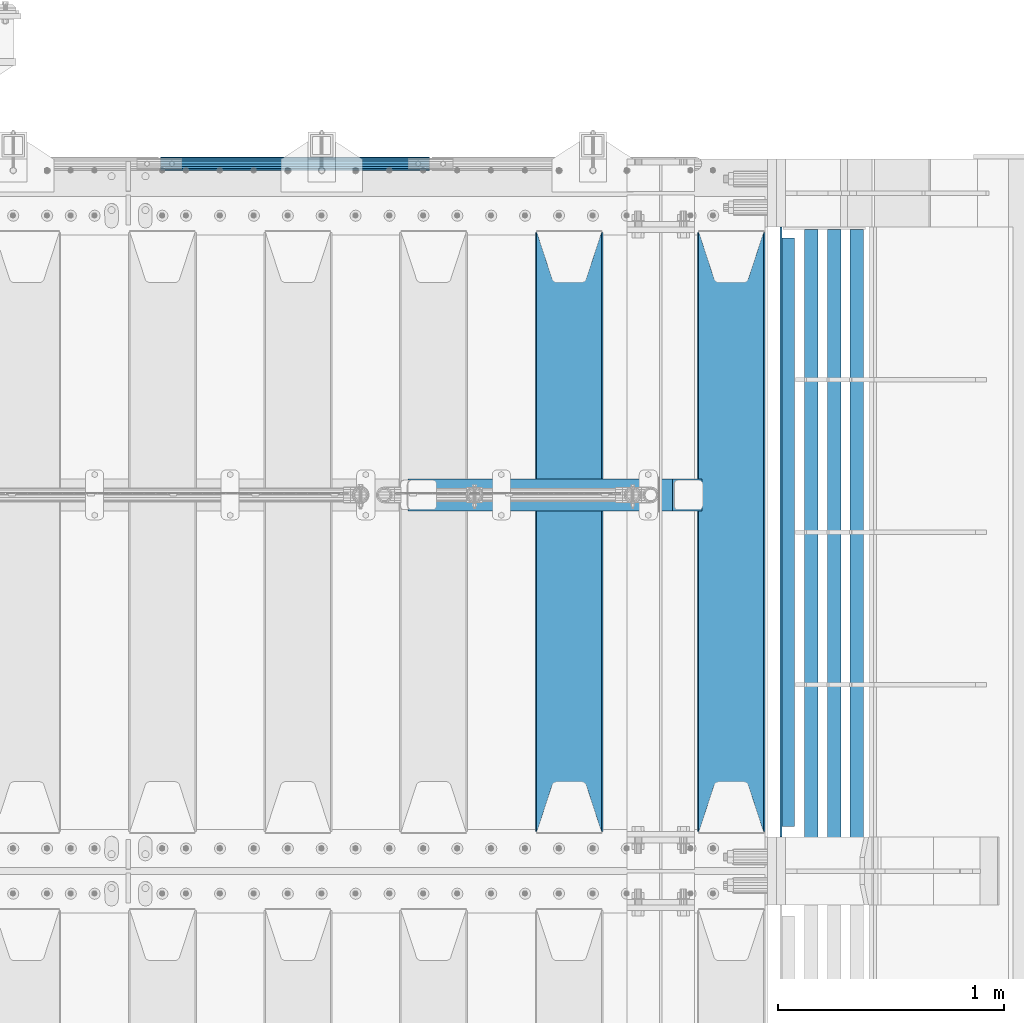
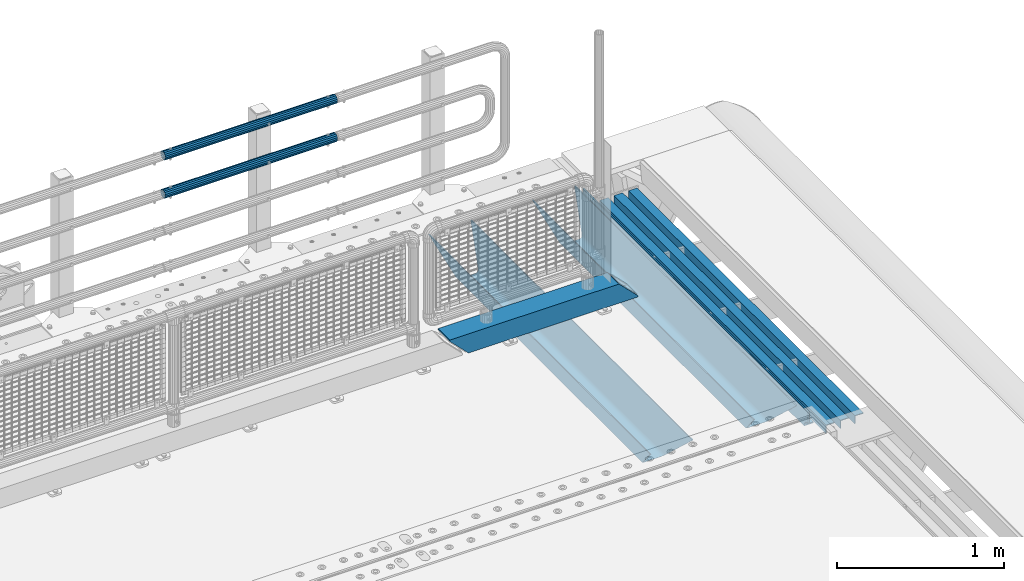
# One storey, part 118 of 219: 9 beams.
"""IFC2X3 building model written with IfcOpenShell, lengths in millimetres."""

from ifc_helpers import new_model, si_unit, frame, origin_with_axes, place, context, subcontext, project, spatial, faceted_brep, material, type_object, element, save


model = new_model("IFC2X3")

# Units and contexts
model_context = context("Model", 3, precision=1e-05, world=origin_with_axes())
body_context = subcontext(model_context, "Body", "Model", "MODEL_VIEW")
ifc_project = project(units=[si_unit("LENGTHUNIT", "METRE", prefix="MILLI"), si_unit("AREAUNIT", "SQUARE_METRE"), si_unit("VOLUMEUNIT", "CUBIC_METRE"), si_unit("MASSUNIT", "GRAM", prefix="KILO"), si_unit("TIMEUNIT", "SECOND"), si_unit("PLANEANGLEUNIT", "RADIAN"), si_unit("SOLIDANGLEUNIT", "STERADIAN"), si_unit("THERMODYNAMICTEMPERATUREUNIT", "DEGREE_CELSIUS"), si_unit("LUMINOUSINTENSITYUNIT", "LUMEN")], contexts=[model_context])

# Site, building, storey
site_placement = place(None, origin_with_axes())
site = spatial("IfcSite", under=ifc_project, at=site_placement, CompositionType="ELEMENT")
building_placement = place(site_placement, origin_with_axes())
building = spatial("IfcBuilding", under=site, at=building_placement, Name="Standard", CompositionType="ELEMENT")
storey_placement = place(building_placement, origin_with_axes())
storey = spatial("IfcBuildingStorey", under=building, at=storey_placement, Name="Undefined", CompositionType="ELEMENT", Elevation=0.0)

# Beams
ifc_material_1 = material(Name="STEEL/S355N")
beam_type_1 = type_object("IfcBeamType", PredefinedType="NOTDEFINED")
beam_1_placement = place(storey_placement, frame((13867.0, 30175.0, -115.0), z_axis=(0.0, 0.0, 1.0), x_axis=(0.0, 1.0, 0.0)))
element("IfcBeam", 1, at=beam_1_placement, inside=storey, type_object=beam_type_1, material=ifc_material_1, context=body_context, shape_type="Brep", body=[
    faceted_brep([(0.0, 150.0, 115.0), (0.0, 143.690000000001, 115.0), (2650.00000000297, 143.690000000001, 115.0), (2650.00000000297, 150.0, 115.0), (2650.00000000297, 142.0595652184, 110.000000003094), (2650.00000000297, 148.3695652184, 110.000000003094), (2441.90079219209, -80.110360073113, -98.0992078077845), (2437.7588105432, -77.5672621345566, -102.241189456673), (2434.06523489747, -74.4080125315541, -105.934765102404), (2430.9108609509, -70.7102721255742, -109.089139048974), (2428.37322971128, -66.5649389910068, -111.626770288588), (2426.51472138055, -62.0739139532889, -113.485278619323), (2425.38102192092, -57.3475956567672, -114.618978078955), (2424.99999999988, -52.5021667386536, -115.0), (2424.99999999988, 52.5021667386536, -115.0), (2425.38102192092, 57.3475956567672, -114.618978078955), (2426.51472138055, 62.0739139532889, -113.485278619323), (2428.37322971128, 66.5649389910068, -111.626770288588), (2430.9108609509, 70.7102721255742, -109.089139048974), (2434.06523489747, 74.4080125315541, -105.934765102404), (2437.7588105432, 77.5672621345566, -102.241189456673), (2441.90079219209, 80.110360073113, -98.0992078077846), (2446.38936140512, 81.9747917625791, -93.6106385947584), (2448.2494850041, 76.2713538057269, -91.7505149957729), (2444.62967112263, 74.7677798626082, -95.3703288772456), (2441.28936334127, 72.7168944282894, -98.710636658607), (2438.31067330439, 70.1691124903828, -101.689326695487), (2435.76682334748, 67.1870637758839, -104.233176652398), (2433.72034654134, 63.8440531834913, -106.279653458539), (2432.22154950042, 60.2222587982342, -107.778450499454), (2431.30727574265, 56.4107117849107, -108.692724257221), (2430.99999999987, 52.5031078186894, -109.0), (2430.99999999987, -52.5031078186894, -109.0), (2431.30727574265, -56.4107117849107, -108.692724257221), (2432.22154950042, -60.2222587982342, -107.778450499454), (2433.72034654134, -63.8440531834913, -106.279653458539), (2435.76682334748, -67.1870637758839, -104.233176652398), (2438.31067330439, -70.1691124903828, -101.689326695487), (2441.28936334127, -72.7168944282894, -98.7106366586071), (2444.62967112263, -74.7677798626082, -95.3703288772457), (2448.2494850041, -76.2713538057269, -91.7505149957729), (2650.00000000297, -142.0595652184, 110.000000003094), (2650.00000000297, -148.3695652184, 110.000000003094), (2446.38936140512, -81.9747917625791, -93.6106385947584), (2650.00000000297, -143.690000000001, 115.0), (2650.00000000297, -150.0, 115.0), (0.0, -143.690000000001, 115.0), (0.0, -150.0, 115.0), (0.0, -148.369565218261, 110.000000002667), (203.610638597427, -81.9747917625791, -93.6106385947584), (208.09920781045, -80.110360073113, -98.0992078077845), (212.241189459342, -77.5672621345566, -102.241189456673), (215.93476510507, -74.4080125315541, -105.934765102404), (219.089139051641, -70.7102721255742, -109.089139048974), (221.626770291256, -66.5649389910068, -111.626770288588), (223.485278621989, -62.0739139532889, -113.485278619323), (224.618978081624, -57.3475956567672, -114.618978078955), (225.000000002663, -52.5021667386536, -115.0), (225.000000002663, 52.5021667386536, -115.0), (224.618978081624, 57.3475956567672, -114.618978078955), (223.485278621989, 62.0739139532889, -113.485278619323), (221.626770291256, 66.5649389910068, -111.626770288588), (219.089139051641, 70.7102721255742, -109.089139048974), (215.93476510507, 74.4080125315541, -105.934765102404), (212.241189459342, 77.5672621345566, -102.241189456673), (208.09920781045, 80.110360073113, -98.0992078077846), (203.610638597427, 81.9747917625791, -93.6106385947584), (0.0, 148.369565218261, 110.000000002667), (0.0, 142.059565218262, 110.000000002667), (201.750514998439, 76.2713538057269, -91.7505149957729), (205.370328879915, 74.7677798626082, -95.3703288772456), (208.710636661275, 72.7168944282894, -98.710636658607), (211.689326698157, 70.1691124903828, -101.689326695487), (214.233176655063, 67.1870637758839, -104.233176652398), (216.279653461206, 63.8440531834913, -106.279653458539), (217.778450502123, 60.2222587982342, -107.778450499454), (218.69272425989, 56.4107117849107, -108.692724257221), (219.00000000267, 52.5031078186894, -109.0), (219.00000000267, -52.5031078186894, -109.0), (218.69272425989, -56.4107117849107, -108.692724257221), (217.778450502123, -60.2222587982342, -107.778450499454), (216.279653461206, -63.8440531834913, -106.279653458539), (214.233176655063, -67.1870637758839, -104.233176652398), (211.689326698157, -70.1691124903828, -101.689326695487), (208.710636661275, -72.7168944282894, -98.7106366586071), (205.370328879915, -74.7677798626082, -95.3703288772457), (201.750514998439, -76.2713538057269, -91.7505149957729), (0.0, -142.059565218262, 110.000000002667)], [[[0, 1, 2, 3]], [[3, 2, 4, 5]], [[6, 7, 8, 9, 10, 11, 12, 13, 14, 15, 16, 17, 18, 19, 20, 21, 22, 5, 4, 23, 24, 25, 26, 27, 28, 29, 30, 31, 32, 33, 34, 35, 36, 37, 38, 39, 40, 41, 42, 43]], [[44, 45, 42, 41]], [[46, 47, 45, 44]], [[43, 42, 45, 47, 48, 49]], [[6, 43, 49, 50]], [[7, 6, 50, 51]], [[8, 7, 51, 52]], [[9, 8, 52, 53]], [[10, 9, 53, 54]], [[11, 10, 54, 55]], [[12, 11, 55, 56]], [[13, 12, 56, 57]], [[14, 13, 57, 58]], [[15, 14, 58, 59]], [[16, 15, 59, 60]], [[17, 16, 60, 61]], [[18, 17, 61, 62]], [[19, 18, 62, 63]], [[20, 19, 63, 64]], [[21, 20, 64, 65]], [[22, 21, 65, 66]], [[0, 3, 5, 22, 66, 67]], [[1, 0, 67, 68]], [[23, 4, 2, 1, 68, 69]], [[24, 23, 69, 70]], [[25, 24, 70, 71]], [[26, 25, 71, 72]], [[27, 26, 72, 73]], [[28, 27, 73, 74]], [[29, 28, 74, 75]], [[30, 29, 75, 76]], [[31, 30, 76, 77]], [[32, 31, 77, 78]], [[33, 32, 78, 79]], [[34, 33, 79, 80]], [[35, 34, 80, 81]], [[36, 35, 81, 82]], [[37, 36, 82, 83]], [[38, 37, 83, 84]], [[39, 38, 84, 85]], [[40, 39, 85, 86]], [[46, 44, 41, 40, 86, 87]], [[47, 46, 87, 48]], [[86, 85, 84, 83, 82, 81, 80, 79, 78, 77, 76, 75, 74, 73, 72, 71, 70, 69, 68, 67, 66, 65, 64, 63, 62, 61, 60, 59, 58, 57, 56, 55, 54, 53, 52, 51, 50, 49, 48, 87]]]),
])
beam_2_placement = place(storey_placement, frame((13150.0, 30175.0, -115.0), z_axis=(0.0, 0.0, 1.0), x_axis=(0.0, 1.0, 0.0)))
element("IfcBeam", 2, at=beam_2_placement, inside=storey, type_object=beam_type_1, material=ifc_material_1, context=body_context, shape_type="Brep", body=[
    faceted_brep([(0.0, 150.0, 115.0), (0.0, 143.690000000001, 115.0), (2650.00000000297, 143.690000000001, 115.0), (2650.00000000297, 150.0, 115.0), (2650.00000000297, 142.0595652184, 110.000000003094), (2650.00000000297, 148.3695652184, 110.000000003094), (2441.90079219209, -80.110360073113, -98.0992078077845), (2437.7588105432, -77.5672621345566, -102.241189456673), (2434.06523489747, -74.4080125315541, -105.934765102404), (2430.9108609509, -70.7102721255742, -109.089139048974), (2428.37322971128, -66.5649389910068, -111.626770288588), (2426.51472138055, -62.0739139532889, -113.485278619323), (2425.38102192092, -57.3475956567672, -114.618978078955), (2424.99999999988, -52.5021667386536, -115.0), (2424.99999999988, 52.5021667386536, -115.0), (2425.38102192092, 57.3475956567672, -114.618978078955), (2426.51472138055, 62.0739139532889, -113.485278619323), (2428.37322971128, 66.5649389910068, -111.626770288588), (2430.9108609509, 70.7102721255742, -109.089139048974), (2434.06523489747, 74.4080125315541, -105.934765102404), (2437.7588105432, 77.5672621345566, -102.241189456673), (2441.90079219209, 80.110360073113, -98.0992078077846), (2446.38936140512, 81.9747917625791, -93.6106385947584), (2448.2494850041, 76.2713538057269, -91.7505149957729), (2444.62967112263, 74.7677798626082, -95.3703288772456), (2441.28936334127, 72.7168944282894, -98.710636658607), (2438.31067330439, 70.1691124903828, -101.689326695487), (2435.76682334748, 67.1870637758839, -104.233176652398), (2433.72034654134, 63.8440531834913, -106.279653458539), (2432.22154950042, 60.2222587982342, -107.778450499454), (2431.30727574265, 56.4107117849107, -108.692724257221), (2430.99999999987, 52.5031078186894, -109.0), (2430.99999999987, -52.5031078186894, -109.0), (2431.30727574265, -56.4107117849107, -108.692724257221), (2432.22154950042, -60.2222587982342, -107.778450499454), (2433.72034654134, -63.8440531834913, -106.279653458539), (2435.76682334748, -67.1870637758839, -104.233176652398), (2438.31067330439, -70.1691124903828, -101.689326695487), (2441.28936334127, -72.7168944282894, -98.7106366586071), (2444.62967112263, -74.7677798626082, -95.3703288772457), (2448.2494850041, -76.2713538057269, -91.7505149957729), (2650.00000000297, -142.0595652184, 110.000000003094), (2650.00000000297, -148.3695652184, 110.000000003094), (2446.38936140512, -81.9747917625791, -93.6106385947584), (2650.00000000297, -143.690000000001, 115.0), (2650.00000000297, -150.0, 115.0), (0.0, -143.690000000001, 115.0), (0.0, -150.0, 115.0), (0.0, -148.369565218261, 110.000000002667), (203.610638597427, -81.9747917625791, -93.6106385947584), (208.09920781045, -80.110360073113, -98.0992078077845), (212.241189459342, -77.5672621345566, -102.241189456673), (215.93476510507, -74.4080125315541, -105.934765102404), (219.089139051641, -70.7102721255742, -109.089139048974), (221.626770291256, -66.5649389910068, -111.626770288588), (223.485278621989, -62.0739139532889, -113.485278619323), (224.618978081624, -57.3475956567672, -114.618978078955), (225.000000002663, -52.5021667386536, -115.0), (225.000000002663, 52.5021667386536, -115.0), (224.618978081624, 57.3475956567672, -114.618978078955), (223.485278621989, 62.0739139532889, -113.485278619323), (221.626770291256, 66.5649389910068, -111.626770288588), (219.089139051641, 70.7102721255742, -109.089139048974), (215.93476510507, 74.4080125315541, -105.934765102404), (212.241189459342, 77.5672621345566, -102.241189456673), (208.09920781045, 80.110360073113, -98.0992078077846), (203.610638597427, 81.9747917625791, -93.6106385947584), (0.0, 148.369565218261, 110.000000002667), (0.0, 142.059565218262, 110.000000002667), (201.750514998439, 76.2713538057269, -91.7505149957729), (205.370328879915, 74.7677798626082, -95.3703288772456), (208.710636661275, 72.7168944282894, -98.710636658607), (211.689326698157, 70.1691124903828, -101.689326695487), (214.233176655063, 67.1870637758839, -104.233176652398), (216.279653461206, 63.8440531834913, -106.279653458539), (217.778450502123, 60.2222587982342, -107.778450499454), (218.69272425989, 56.4107117849107, -108.692724257221), (219.00000000267, 52.5031078186894, -109.0), (219.00000000267, -52.5031078186894, -109.0), (218.69272425989, -56.4107117849107, -108.692724257221), (217.778450502123, -60.2222587982342, -107.778450499454), (216.279653461206, -63.8440531834913, -106.279653458539), (214.233176655063, -67.1870637758839, -104.233176652398), (211.689326698157, -70.1691124903828, -101.689326695487), (208.710636661275, -72.7168944282894, -98.7106366586071), (205.370328879915, -74.7677798626082, -95.3703288772457), (201.750514998439, -76.2713538057269, -91.7505149957729), (0.0, -142.059565218262, 110.000000002667)], [[[0, 1, 2, 3]], [[3, 2, 4, 5]], [[6, 7, 8, 9, 10, 11, 12, 13, 14, 15, 16, 17, 18, 19, 20, 21, 22, 5, 4, 23, 24, 25, 26, 27, 28, 29, 30, 31, 32, 33, 34, 35, 36, 37, 38, 39, 40, 41, 42, 43]], [[44, 45, 42, 41]], [[46, 47, 45, 44]], [[43, 42, 45, 47, 48, 49]], [[6, 43, 49, 50]], [[7, 6, 50, 51]], [[8, 7, 51, 52]], [[9, 8, 52, 53]], [[10, 9, 53, 54]], [[11, 10, 54, 55]], [[12, 11, 55, 56]], [[13, 12, 56, 57]], [[14, 13, 57, 58]], [[15, 14, 58, 59]], [[16, 15, 59, 60]], [[17, 16, 60, 61]], [[18, 17, 61, 62]], [[19, 18, 62, 63]], [[20, 19, 63, 64]], [[21, 20, 64, 65]], [[22, 21, 65, 66]], [[0, 3, 5, 22, 66, 67]], [[1, 0, 67, 68]], [[23, 4, 2, 1, 68, 69]], [[24, 23, 69, 70]], [[25, 24, 70, 71]], [[26, 25, 71, 72]], [[27, 26, 72, 73]], [[28, 27, 73, 74]], [[29, 28, 74, 75]], [[30, 29, 75, 76]], [[31, 30, 76, 77]], [[32, 31, 77, 78]], [[33, 32, 78, 79]], [[34, 33, 79, 80]], [[35, 34, 80, 81]], [[36, 35, 81, 82]], [[37, 36, 82, 83]], [[38, 37, 83, 84]], [[39, 38, 84, 85]], [[40, 39, 85, 86]], [[46, 44, 41, 40, 86, 87]], [[47, 46, 87, 48]], [[86, 85, 84, 83, 82, 81, 80, 79, 78, 77, 76, 75, 74, 73, 72, 71, 70, 69, 68, 67, 66, 65, 64, 63, 62, 61, 60, 59, 58, 57, 56, 55, 54, 53, 52, 51, 50, 49, 48, 87]]]),
])
ifc_material_2 = material(Name="STEEL/S355J2")
beam_type_2 = type_object("IfcBeamType", PredefinedType="NOTDEFINED")
beam_3_placement = place(storey_placement, frame((14114.5025260065, 30150.0, -124.999999999993), z_axis=(0.0, 0.0, 1.0), x_axis=(0.0, 1.0, 0.0)))
element("IfcBeam", 3, at=beam_3_placement, inside=storey, type_object=beam_type_2, material=ifc_material_2, context=body_context, shape_type="Brep", body=[
    faceted_brep([(2700.0, 22.5, -15.0), (2684.54915028125, 22.5000000000018, -17.4471741852423), (2684.54915028125, 32.5, -17.4471741852423), (2700.0, 32.5, -15.0), (2670.61073738538, 22.5000000000018, -24.5491502812526), (2670.61073738538, 32.5, -24.5491502812526), (2659.54915028125, 22.5000000000018, -35.6107373853764), (2659.54915028125, 32.5, -35.6107373853764), (2652.44717418524, 22.5000000000018, -49.5491502812526), (2652.44717418524, 32.5, -49.5491502812526), (2651.58384440325, -32.5, -55.0), (2650.0, -32.5, -65.0), (2650.0, 32.5, -65.0), (2651.58384440325, 22.5, -55.0), (0.0, 32.5, 65.0), (0.0, 22.5, 65.0), (2700.0, 22.5, 65.0), (2700.0, 32.5, 65.0), (0.0, 32.5, -15.0), (0.0, 22.5, -15.0), (15.4508497187489, 32.5, -17.4471741852423), (15.4508497187489, 22.5, -17.4471741852423), (29.3892626146226, 32.5, -24.5491502812526), (29.3892626146226, 22.5, -24.5491502812526), (40.4508497187489, 32.5, -35.6107373853763), (40.4508497187489, 22.5, -35.6107373853763), (47.5528258147569, 32.5, -49.5491502812526), (47.5528258147569, 22.5, -49.5491502812526), (50.0, -32.5, -65.0), (48.4161555967512, -32.5, -55.0), (48.4161555967512, 22.5, -55.0), (50.0, 32.5, -65.0)], [[[0, 1, 2, 3]], [[4, 5, 2, 1]], [[6, 7, 5, 4]], [[8, 9, 7, 6]], [[10, 11, 12, 9, 8, 13]], [[14, 15, 16, 17]], [[15, 14, 18, 19]], [[19, 18, 20, 21]], [[21, 20, 22, 23]], [[23, 22, 24, 25]], [[25, 24, 26, 27]], [[28, 29, 30, 27, 26, 31]], [[30, 29, 10, 13]], [[16, 15, 19, 21, 23, 25, 27, 30, 13, 8, 6, 4, 1, 0]], [[17, 16, 0, 3]], [[5, 7, 9, 12, 31, 26, 24, 22, 20, 18, 14, 17, 3, 2]], [[28, 31, 12, 11]], [[29, 28, 11, 10]]]),
])
beam_type_3 = type_object("IfcBeamType", PredefinedType="NOTDEFINED")
for number, where, z_axis, x_axis in (
    (4, (14421.998829901, 32839.9999004142, -209.999999999564), (0.0, 0.0, -1.0), (0.0, -1.0, 0.0)),
    (5, (14321.998829901, 32839.9999004143, -209.999999999564), (0.0, 0.0, -1.0), (0.0, -1.0, 0.0)),
    (6, (14221.9988299003, 32840.0000023388, -209.999999999622), (0.0, 0.0, -1.0), (0.0, -1.0, 0.0)),
):
    element("IfcBeam", number, at=place(storey_placement, frame(where, z_axis=z_axis, x_axis=x_axis)), inside=storey, type_object=beam_type_3, material=ifc_material_2, context=body_context, shape_type="Brep", body=[
        faceted_brep([(3.63797880709171e-12, 29.9999999999982, -30.0), (0.0, 29.9999999999982, 30.0), (2710.00017042502, 30.0, 30.0), (2710.00017042501, 30.0, -30.0), (0.0, 23.9999999999982, 30.0), (2710.00017042502, 24.0, 30.0), (0.0, 23.9999999999982, -24.0), (2710.00017042502, 24.0, -24.0), (3.63797880709171e-12, -30.0000000000018, -24.0), (2710.00017042502, -30.0, -24.0), (3.63797880709171e-12, -30.0000000000018, -30.0), (2710.00017042501, -30.0, -30.0)], [[[0, 1, 2, 3]], [[1, 4, 5, 2]], [[4, 6, 7, 5]], [[6, 8, 9, 7]], [[8, 10, 11, 9]], [[10, 0, 3, 11]], [[5, 7, 9, 11, 3, 2]], [[10, 8, 6, 4, 1, 0]]]),
    ])
ifc_material_3 = material()
beam_type_4 = type_object("IfcBeamType", PredefinedType="NOTDEFINED")
beam_4_placement = place(storey_placement, frame((12437.0, 31664.5, 98.0199999999977), z_axis=(0.0, 0.0, 1.0), x_axis=(1.0, 0.0, 0.0)))
element("IfcBeam", 7, at=beam_4_placement, inside=storey, type_object=beam_type_4, material=ifc_material_3, context=body_context, shape_type="Brep", body=[
    faceted_brep([(0.0, 70.0, 70.0), (0.0, -70.0, 70.0), (1170.88846984783, -70.0, 70.0), (1170.88846984783, 70.0, 70.0), (1301.0, -60.0, -60.0), (1301.0, 60.0, -60.0), (119.989831466437, 60.0, -60.0), (119.989910626171, -60.0, -60.0), (1180.89643628727, -60.0, 60.0), (2.49929144047201e-09, -60.0, 60.0), (2.49929144047201e-09, 60.0000000000036, 60.0), (1180.89643628727, 60.0, 60.0), (1301.0, -70.0, -60.0079600980745), (1301.0, 70.0, -60.0079600980745), (1301.0, -70.0, -70.0), (1301.0, 70.0, -70.0), (129.999907566678, 70.0, -70.0), (0.0, 70.0, 59.8689646261531), (0.0, -70.0, 59.8690568861524), (129.999999919701, -70.0, -70.0)], [[[0, 1, 2, 3]], [[4, 5, 6, 7]], [[8, 4, 7, 9]], [[9, 10, 11, 8]], [[5, 11, 10, 6]], [[2, 12, 4, 8, 11, 5, 13, 3]], [[4, 12, 14, 15, 13, 5]], [[0, 3, 13, 15, 16, 17]], [[9, 18, 1, 0, 17, 10]], [[14, 12, 2, 1, 18, 19]], [[15, 14, 19, 16]], [[18, 9, 7, 6, 10, 17, 16, 19]]]),
])
beam_type_5 = type_object("IfcBeamType", PredefinedType="NOTDEFINED")
beam_5_placement = place(storey_placement, frame((11342.0000000001, 33129.8499999996, 969.549999999748), z_axis=(0.0, -1.0, 0.0), x_axis=(1.0, 0.0, 0.0)))
element("IfcBeam", 8, at=beam_5_placement, inside=storey, type_object=beam_type_5, material=ifc_material_3, context=body_context, shape_type="Brep", body=[
    faceted_brep([(0.0, -26.5500000000029, 0.0), (0.0, -24.5290015881765, 10.1602451292931), (1190.0, -24.5290015881747, 10.1602451292929), (1190.0, -26.55, 0.0), (0.0, -18.7736850405054, 18.7736850405028), (1190.0, -18.7736850405028, 18.7736850405054), (0.0, -10.1602451292929, 24.5290015881747), (1190.0, -10.1602451292931, 24.5290015881765), (0.0, 0.0, 26.55), (1190.0, 0.0, 26.5500000000029), (0.0, 10.1602451292929, 24.5290015881747), (1190.0, 10.1602451292932, 24.5290015881765), (0.0, 18.7736850405054, 18.7736850405028), (1190.0, 18.7736850405029, 18.7736850405054), (0.0, 24.5290015881765, 10.1602451292931), (1190.0, 24.5290015881747, 10.1602451292929), (0.0, 26.5500000000029, 0.0), (1190.0, 26.55, 0.0), (0.0, 24.5290015881765, -10.1602451292931), (1190.0, 24.5290015881747, -10.1602451292929), (0.0, 18.7736850405054, -18.7736850405028), (1190.0, 18.7736850405028, -18.7736850405054), (0.0, 10.1602451292929, -24.5290015881747), (1190.0, 10.1602451292931, -24.5290015881765), (0.0, 0.0, -26.55), (1190.0, 0.0, -26.5500000000029), (0.0, -10.1602451292929, -24.5290015881747), (1190.0, -10.1602451292931, -24.5290015881765), (0.0, -18.7736850405054, -18.7736850405028), (1190.0, -18.7736850405028, -18.7736850405054), (0.0, -24.5290015881765, -10.1602451292931), (1190.0, -24.5290015881747, -10.1602451292929), (0.0, -30.1500000000015, 0.0), (0.0, -27.8549679052157, -11.5379054858076), (1190.0, -27.8549679052153, -11.5379054858058), (1190.0, -30.15, 0.0), (0.0, -21.3192694527752, -21.3192694527752), (1190.0, -21.3192694527744, -21.3192694527752), (0.0, -11.5379054858058, -27.8549679052157), (1190.0, -11.5379054858075, -27.8549679052157), (0.0, 0.0, -30.1499999999996), (1190.0, 0.0, -30.1500000000015), (0.0, 11.5379054858058, -27.8549679052157), (1190.0, 11.5379054858075, -27.8549679052157), (0.0, 21.3192694527752, -21.3192694527752), (1190.0, 21.3192694527744, -21.3192694527752), (0.0, 27.8549679052157, -11.5379054858076), (1190.0, 27.8549679052153, -11.5379054858058), (0.0, 30.1500000000015, 0.0), (1190.0, 30.15, 0.0), (0.0, 27.8549679052157, 11.5379054858076), (1190.0, 27.8549679052153, 11.5379054858058), (0.0, 21.3192694527752, 21.3192694527752), (1190.0, 21.3192694527744, 21.3192694527752), (0.0, 11.5379054858058, 27.8549679052157), (1190.0, 11.5379054858075, 27.8549679052157), (0.0, 0.0, 30.1499999999996), (1190.0, 0.0, 30.1500000000015), (0.0, -11.5379054858058, 27.8549679052157), (1190.0, -11.5379054858075, 27.8549679052157), (0.0, -21.3192694527752, 21.3192694527752), (1190.0, -21.3192694527744, 21.3192694527752), (0.0, -27.8549679052157, 11.5379054858076), (1190.0, -27.8549679052153, 11.5379054858058)], [[[0, 1, 2, 3]], [[1, 4, 5, 2]], [[4, 6, 7, 5]], [[6, 8, 9, 7]], [[8, 10, 11, 9]], [[10, 12, 13, 11]], [[12, 14, 15, 13]], [[14, 16, 17, 15]], [[16, 18, 19, 17]], [[18, 20, 21, 19]], [[20, 22, 23, 21]], [[22, 24, 25, 23]], [[24, 26, 27, 25]], [[26, 28, 29, 27]], [[28, 30, 31, 29]], [[30, 0, 3, 31]], [[32, 33, 34, 35]], [[33, 36, 37, 34]], [[36, 38, 39, 37]], [[38, 40, 41, 39]], [[40, 42, 43, 41]], [[42, 44, 45, 43]], [[44, 46, 47, 45]], [[46, 48, 49, 47]], [[48, 50, 51, 49]], [[50, 52, 53, 51]], [[52, 54, 55, 53]], [[54, 56, 57, 55]], [[56, 58, 59, 57]], [[58, 60, 61, 59]], [[60, 62, 63, 61]], [[62, 32, 35, 63]], [[37, 39, 41, 43, 45, 47, 49, 51, 53, 55, 57, 59, 61, 63, 35, 34], [5, 7, 9, 11, 13, 15, 17, 19, 21, 23, 25, 27, 29, 31, 3, 2]], [[62, 60, 58, 56, 54, 52, 50, 48, 46, 44, 42, 40, 38, 36, 33, 32], [30, 28, 26, 24, 22, 20, 18, 16, 14, 12, 10, 8, 6, 4, 1, 0]]]),
])
beam_6_placement = place(storey_placement, frame((11342.0000000001, 33129.8499999996, 689.549999999748), z_axis=(0.0, -1.0, 0.0), x_axis=(1.0, 0.0, 0.0)))
element("IfcBeam", 9, at=beam_6_placement, inside=storey, type_object=beam_type_5, material=ifc_material_3, context=body_context, shape_type="Brep", body=[
    faceted_brep([(0.0, -26.5500000000029, 0.0), (0.0, -24.5290015881765, 10.1602451292931), (1190.0, -24.5290015881747, 10.1602451292929), (1190.0, -26.55, 0.0), (0.0, -18.7736850405054, 18.7736850405028), (1190.0, -18.7736850405028, 18.7736850405054), (0.0, -10.1602451292929, 24.5290015881747), (1190.0, -10.1602451292931, 24.5290015881765), (0.0, 0.0, 26.55), (1190.0, 0.0, 26.5500000000029), (0.0, 10.1602451292929, 24.5290015881747), (1190.0, 10.1602451292932, 24.5290015881765), (0.0, 18.7736850405054, 18.7736850405028), (1190.0, 18.7736850405029, 18.7736850405054), (0.0, 24.5290015881765, 10.1602451292931), (1190.0, 24.5290015881747, 10.1602451292929), (0.0, 26.5500000000029, 0.0), (1190.0, 26.55, 0.0), (0.0, 24.5290015881765, -10.1602451292931), (1190.0, 24.5290015881747, -10.1602451292929), (0.0, 18.7736850405054, -18.7736850405028), (1190.0, 18.7736850405028, -18.7736850405054), (0.0, 10.1602451292929, -24.5290015881747), (1190.0, 10.1602451292931, -24.5290015881765), (0.0, 0.0, -26.55), (1190.0, 0.0, -26.5500000000029), (0.0, -10.1602451292929, -24.5290015881747), (1190.0, -10.1602451292931, -24.5290015881765), (0.0, -18.7736850405054, -18.7736850405028), (1190.0, -18.7736850405028, -18.7736850405054), (0.0, -24.5290015881765, -10.1602451292931), (1190.0, -24.5290015881747, -10.1602451292929), (0.0, -30.1500000000015, 0.0), (0.0, -27.8549679052157, -11.5379054858076), (1190.0, -27.8549679052153, -11.5379054858058), (1190.0, -30.15, 0.0), (0.0, -21.3192694527752, -21.3192694527752), (1190.0, -21.3192694527744, -21.3192694527752), (0.0, -11.5379054858058, -27.8549679052157), (1190.0, -11.5379054858075, -27.8549679052157), (0.0, 0.0, -30.1499999999996), (1190.0, 0.0, -30.1500000000015), (0.0, 11.5379054858058, -27.8549679052157), (1190.0, 11.5379054858075, -27.8549679052157), (0.0, 21.3192694527752, -21.3192694527752), (1190.0, 21.3192694527744, -21.3192694527752), (0.0, 27.8549679052157, -11.5379054858076), (1190.0, 27.8549679052153, -11.5379054858058), (0.0, 30.1500000000015, 0.0), (1190.0, 30.15, 0.0), (0.0, 27.8549679052157, 11.5379054858076), (1190.0, 27.8549679052153, 11.5379054858058), (0.0, 21.3192694527752, 21.3192694527752), (1190.0, 21.3192694527744, 21.3192694527752), (0.0, 11.5379054858058, 27.8549679052157), (1190.0, 11.5379054858075, 27.8549679052157), (0.0, 0.0, 30.1499999999996), (1190.0, 0.0, 30.1500000000015), (0.0, -11.5379054858058, 27.8549679052157), (1190.0, -11.5379054858075, 27.8549679052157), (0.0, -21.3192694527752, 21.3192694527752), (1190.0, -21.3192694527744, 21.3192694527752), (0.0, -27.8549679052157, 11.5379054858076), (1190.0, -27.8549679052153, 11.5379054858058)], [[[0, 1, 2, 3]], [[1, 4, 5, 2]], [[4, 6, 7, 5]], [[6, 8, 9, 7]], [[8, 10, 11, 9]], [[10, 12, 13, 11]], [[12, 14, 15, 13]], [[14, 16, 17, 15]], [[16, 18, 19, 17]], [[18, 20, 21, 19]], [[20, 22, 23, 21]], [[22, 24, 25, 23]], [[24, 26, 27, 25]], [[26, 28, 29, 27]], [[28, 30, 31, 29]], [[30, 0, 3, 31]], [[32, 33, 34, 35]], [[33, 36, 37, 34]], [[36, 38, 39, 37]], [[38, 40, 41, 39]], [[40, 42, 43, 41]], [[42, 44, 45, 43]], [[44, 46, 47, 45]], [[46, 48, 49, 47]], [[48, 50, 51, 49]], [[50, 52, 53, 51]], [[52, 54, 55, 53]], [[54, 56, 57, 55]], [[56, 58, 59, 57]], [[58, 60, 61, 59]], [[60, 62, 63, 61]], [[62, 32, 35, 63]], [[37, 39, 41, 43, 45, 47, 49, 51, 53, 55, 57, 59, 61, 63, 35, 34], [5, 7, 9, 11, 13, 15, 17, 19, 21, 23, 25, 27, 29, 31, 3, 2]], [[62, 60, 58, 56, 54, 52, 50, 48, 46, 44, 42, 40, 38, 36, 33, 32], [30, 28, 26, 24, 22, 20, 18, 16, 14, 12, 10, 8, 6, 4, 1, 0]]]),
])

save(model, "model.ifc")
